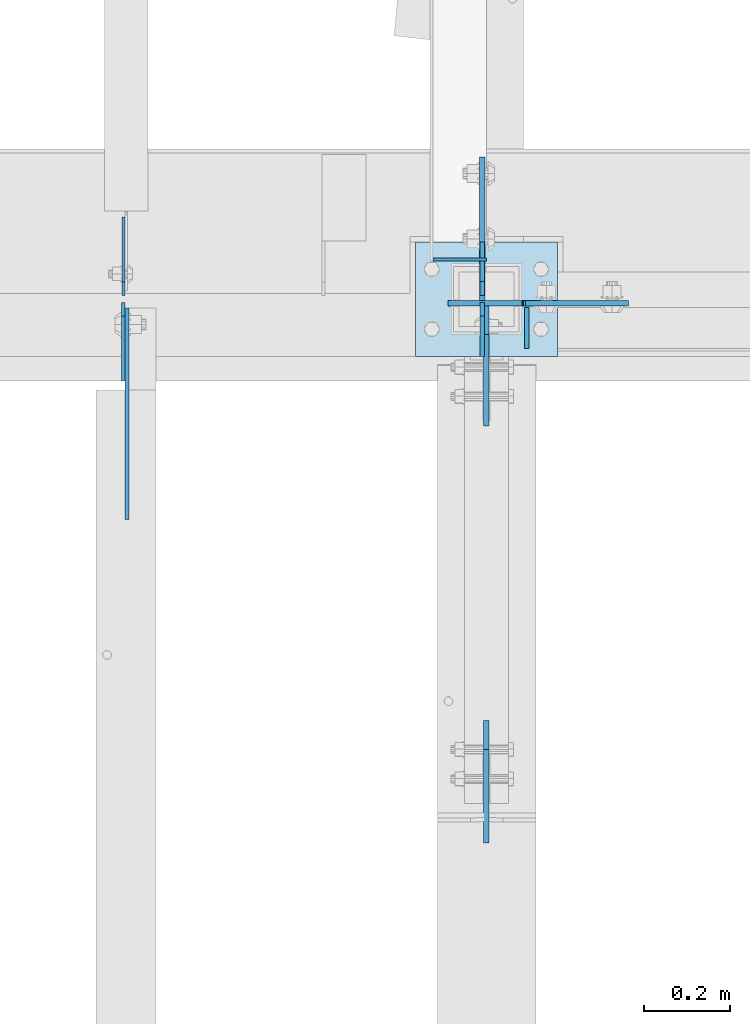
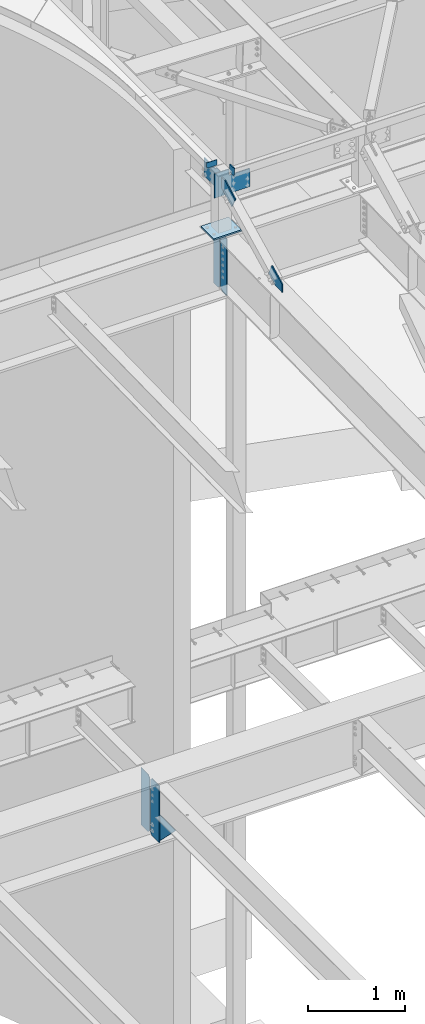
# One storey, part 1633 of 1763: 12 plates, 7 elements without a shape of their own.
"""IFC2X3 building model written with IfcOpenShell, lengths in millimetres."""

from ifc_helpers import new_model, si_unit, frame, origin_with_axes, place, context, subcontext, project, spatial, faceted_brep, material, type_object, element, aggregate, save


model = new_model("IFC2X3")

# Units and contexts
model_context = context("Model", 3, precision=1e-05, world=origin_with_axes())
body_context = subcontext(model_context, "Body", "Model", "MODEL_VIEW")
ifc_project = project(units=[si_unit("LENGTHUNIT", "METRE", prefix="MILLI"), si_unit("AREAUNIT", "SQUARE_METRE"), si_unit("VOLUMEUNIT", "CUBIC_METRE"), si_unit("MASSUNIT", "GRAM", prefix="KILO"), si_unit("TIMEUNIT", "SECOND"), si_unit("PLANEANGLEUNIT", "RADIAN"), si_unit("SOLIDANGLEUNIT", "STERADIAN"), si_unit("THERMODYNAMICTEMPERATUREUNIT", "DEGREE_CELSIUS"), si_unit("LUMINOUSINTENSITYUNIT", "LUMEN")], contexts=[model_context])

# Site, building, storey
site_placement = place(None, origin_with_axes())
site = spatial("IfcSite", under=ifc_project, at=site_placement, CompositionType="ELEMENT")
building_placement = place(site_placement, origin_with_axes())
building = spatial("IfcBuilding", under=site, at=building_placement, Name="Undefined", CompositionType="ELEMENT")
storey_placement = place(building_placement, origin_with_axes())
storey = spatial("IfcBuildingStorey", under=building, at=storey_placement, Name="Undefined", CompositionType="ELEMENT", Elevation=0.0)

# Assembly, plate
assembly_1_placement = place(storey_placement, origin_with_axes())
assembly_1 = element("IfcElementAssembly", 1, at=assembly_1_placement, inside=storey, Name="COLUMN", AssemblyPlace="NOTDEFINED", PredefinedType="RIGID_FRAME")
ifc_material_1 = material(Name="STEEL/A572-50")
plate_type_1 = type_object("IfcPlateType", PredefinedType="NOTDEFINED")
plate_1_placement = place(assembly_1_placement, frame((-41255.9882217781, 52111.275, 12484.1), z_axis=(0.0, 0.0, -1.0), x_axis=(-1.0, 0.0, 0.0)))
plate_1 = element("IfcPlate", 2, at=plate_1_placement, type_object=plate_type_1, material=ifc_material_1, Name="PLATE", context=body_context, shape_type="Brep", body=[
    faceted_brep([(-247.649993896484, -6.34999999999854, 76.2000000000007), (-247.649993896484, 6.34999999999854, 76.2000000000007), (-12.6999998092724, 6.34999999999854, 76.2000000000007), (-12.6999998092724, -6.34999999999854, 76.2000000000007), (-7.83992029122601, 6.34999999999854, 75.2332700774132), (-7.83992029122601, -6.34999999999854, 75.2332700774132), (-3.71974382307235, 6.34999999999854, 72.4802561769357), (-3.71974382307235, -6.34999999999854, 72.4802561769357), (-0.966729922598461, 6.34999999999854, 68.360079708782), (-0.966729922598461, -6.34999999999854, 68.360079708782), (-7.27595761418343e-12, -6.34999999999854, 63.5000001907356), (-7.27595761418343e-12, 6.34999999999854, 63.5000001907356), (0.0, 6.34999999999491, -2.91038304567337e-11), (0.0, -6.34999999999491, 1.45519152283669e-11), (-247.649993896484, -6.34999999999854, 304.799987792969), (171.449996948242, -6.34999999999854, 304.799987792969), (171.449996948242, 6.34999999999854, 304.799987792969), (-247.649993896484, 6.34999999999854, 304.799987792969), (171.449996948242, -6.34999999999854, 0.0), (171.449996948242, 6.34999999999854, 0.0)], [[[0, 1, 2, 3]], [[3, 2, 4, 5]], [[5, 4, 6, 7]], [[7, 6, 8, 9]], [[10, 11, 12, 13]], [[9, 8, 11, 10]], [[14, 15, 16, 17]], [[15, 18, 19, 16]], [[19, 18, 13, 12]], [[6, 4, 2, 1, 17, 16, 19, 12, 11, 8]], [[14, 17, 1, 0]], [[18, 15, 14, 0, 3, 5, 7, 9, 10, 13]]]),
])

assembly_2_placement = place(storey_placement, origin_with_axes())
assembly_2 = element("IfcElementAssembly", 3, at=assembly_2_placement, inside=storey, Name="BEAM", AssemblyPlace="NOTDEFINED", PredefinedType="RIGID_FRAME")
ifc_material_2 = material(Name="STEEL/A36")
plate_type_2 = type_object("IfcPlateType", PredefinedType="NOTDEFINED")
plate_2_placement = place(assembly_2_placement, frame((-41338.5382217802, 50858.8044431328, 11721.3897393295), z_axis=(0.0, -0.0206852279954837, 0.999786037781472), x_axis=(0.0, 0.999786037781472, 0.0206852279954825)))
plate_2 = element("IfcPlate", 4, at=plate_2_placement, type_object=plate_type_2, material=ifc_material_2, Name="PLATE", context=body_context, shape_type="Brep", body=[
    faceted_brep([(0.0, -6.34999999999491, 1.45519152283669e-11), (1.45519152283669e-11, -6.34999999999854, 101.599998474047), (1.45519152283669e-11, 6.34999999999854, 101.599998474047), (0.0, 6.34999999999491, -2.91038304567337e-11), (218.951583862981, -6.34999999999854, 205.463943481234), (218.951583862981, 6.34999999999854, 205.463943481234), (284.27273559654, -6.34999999999854, 67.7725906370797), (284.27273559654, 6.34999999999854, 67.7725906370797), (141.413955688891, -6.34999999999854, -4.72937244921923e-11), (141.413955688891, 6.34999999999854, -4.72937244921923e-11)], [[[0, 1, 2, 3]], [[1, 4, 5, 2]], [[4, 6, 7, 5]], [[6, 8, 9, 7]], [[8, 0, 3, 9]], [[5, 7, 9, 3, 2]], [[8, 6, 4, 1, 0]]]),
])
aggregate(assembly_2, [plate_2])

# Plate
plate_type_3 = type_object("IfcPlateType", PredefinedType="NOTDEFINED")
plate_3_placement = place(assembly_1_placement, frame((-41338.5382217802, 52104.9250000007, 12416.9092242053), z_axis=(0.0, -1.0, 0.0), x_axis=(0.0, 0.0, -1.0)))
plate_3 = element("IfcPlate", 5, at=plate_3_placement, type_object=plate_type_3, material=ifc_material_2, Name="PLATE", context=body_context, shape_type="Brep", body=[
    faceted_brep([(0.0, -6.34999999999491, 1.45519152283669e-11), (0.0, -6.34999999999854, 66.6750030517578), (0.0, 6.34999999999854, 66.6750030517578), (0.0, 6.34999999999491, -2.91038304567337e-11), (109.25341796875, -6.34999999999854, 278.831817626953), (109.25341796875, 6.34999999999854, 278.831817626953), (245.564117431641, -6.34999999999854, 210.676483154297), (245.564117431641, 6.34999999999854, 210.676483154297), (140.225875854492, -6.34999999999854, 0.0), (140.225875854492, 6.34999999999854, 0.0)], [[[0, 1, 2, 3]], [[1, 4, 5, 2]], [[4, 6, 7, 5]], [[6, 8, 9, 7]], [[8, 0, 3, 9]], [[5, 7, 9, 3, 2]], [[8, 6, 4, 1, 0]]]),
])

# Assembly, plate
assembly_3_placement = place(storey_placement, origin_with_axes())
assembly_3 = element("IfcElementAssembly", 6, at=assembly_3_placement, inside=storey, Name="BEAM", AssemblyPlace="NOTDEFINED", PredefinedType="RIGID_FRAME")
plate_type_4 = type_object("IfcPlateType", PredefinedType="NOTDEFINED")
plate_4_placement = place(assembly_3_placement, frame((-41244.8757217781, 52101.75, 12452.35), z_axis=(0.0, 0.0, 1.0), x_axis=(0.0, -1.0, 0.0)))
plate_4 = element("IfcPlate", 7, at=plate_4_placement, type_object=plate_type_4, material=ifc_material_2, Name="PLATE", context=body_context, shape_type="Brep", body=[
    faceted_brep([(0.0, -4.76249999999982, 0.0), (0.0, -4.76249999999709, 95.25), (0.0, 4.76249999999709, 95.25), (0.0, 4.76249999999982, 0.0), (95.25, -4.76249999999709, 95.25), (95.25, 4.76249999999709, 95.25), (95.25, -4.76249999999709, 19.0499992370605), (95.25, 4.76249999999709, 19.0499992370605), (76.1999969482931, -4.76249999991705, 0.0), (76.1999969482931, 4.76250000006257, 1.81898940354586e-12)], [[[0, 1, 2, 3]], [[1, 4, 5, 2]], [[4, 6, 7, 5]], [[6, 8, 9, 7]], [[8, 0, 3, 9]], [[5, 7, 9, 3, 2]], [[8, 6, 4, 1, 0]]]),
])
aggregate(assembly_3, [plate_4])

assembly_4_placement = place(storey_placement, origin_with_axes())
assembly_4 = element("IfcElementAssembly", 8, at=assembly_4_placement, inside=storey, Name="BEAM", AssemblyPlace="NOTDEFINED", PredefinedType="RIGID_FRAME")
plate_type_5 = type_object("IfcPlateType", PredefinedType="NOTDEFINED")
plate_5_placement = place(assembly_4_placement, frame((-41463.3380411022, 52212.8535679558, 12501.364063), z_axis=(0.0, 0.0, 1.0), x_axis=(1.0, 0.0, 0.0)))
plate_5 = element("IfcPlate", 9, at=plate_5_placement, type_object=plate_type_5, material=ifc_material_2, Name="PLATE", context=body_context, shape_type="Brep", body=[
    faceted_brep([(0.0, -3.17500000000291, 19.0499992370605), (0.0, -3.17500000000291, 69.8499984741211), (7.27595761418343e-12, 3.17500000000291, 69.8499984741211), (7.27595761418343e-12, 3.17500000000291, 19.0499992370605), (124.799827575684, -3.17500000022847, 69.8499984741211), (124.799827575691, 3.17499999977736, 69.8499984741211), (124.799781799316, -3.17499999999927, 0.0), (124.799781799316, 3.17499999999927, 0.0), (19.0499992370605, -3.17500000003929, 0.0), (19.0499992370678, 3.17499999995925, 0.0)], [[[0, 1, 2, 3]], [[1, 4, 5, 2]], [[4, 6, 7, 5]], [[6, 8, 9, 7]], [[8, 0, 3, 9]], [[5, 7, 9, 3, 2]], [[8, 6, 4, 1, 0]]]),
])
aggregate(assembly_4, [plate_5])

# Assembly, plates
assembly_5_placement = place(storey_placement, origin_with_axes())
assembly_5 = element("IfcElementAssembly", 10, at=assembly_5_placement, inside=storey, Name="BEAM", AssemblyPlace="NOTDEFINED", PredefinedType="RIGID_FRAME")
plate_type_6 = type_object("IfcPlateType", PredefinedType="NOTDEFINED")
plate_6_placement = place(assembly_5_placement, frame((-42182.487273746, 52128.7375, 4448.175), z_axis=(0.0, 0.0, 1.0), x_axis=(0.0, 1.0, 0.0)))
plate_6 = element("IfcPlate", 11, at=plate_6_placement, type_object=plate_type_6, material=ifc_material_2, Name="PLATE", context=body_context, shape_type="Brep", body=[
    faceted_brep([(0.0, -3.17500000000291, 31.75), (0.0, -3.17500000000291, 687.387512207031), (0.0, 3.17500000000291, 687.387512207031), (0.0, 3.17500000000291, 31.75), (31.75, -3.17500000000291, 719.137512207031), (31.75, 3.17500000000291, 719.137512207031), (182.5625, -3.17500000000291, 719.137512207031), (182.5625, 3.17500000000291, 719.137512207031), (182.5625, -3.17500000000291, 0.0), (182.5625, 3.17500000000291, 0.0), (31.7499999999036, -3.17499999997381, 9.42916855706244e-11), (31.7499999998854, 3.17500000000291, 9.42916855706244e-11)], [[[0, 1, 2, 3]], [[1, 4, 5, 2]], [[4, 6, 7, 5]], [[6, 8, 9, 7]], [[8, 10, 11, 9]], [[10, 0, 3, 11]], [[5, 7, 9, 11, 3, 2]], [[10, 8, 6, 4, 1, 0]]]),
])
plate_type_7 = type_object("IfcPlateType", PredefinedType="NOTDEFINED")
plate_7_placement = place(assembly_5_placement, frame((-42183.2820237632, 52112.8625, 4448.175), z_axis=(0.0, 0.0, 1.0), x_axis=(0.0, -1.0, 0.0)))
plate_7 = element("IfcPlate", 12, at=plate_7_placement, type_object=plate_type_7, material=ifc_material_2, Name="PLATE", context=body_context, shape_type="Brep", body=[
    faceted_brep([(0.0, -3.96899999999732, 31.75), (0.0, -3.96899999999732, 687.387512207031), (0.0, 3.96899999999732, 687.387512207031), (0.0, 3.96899999999732, 31.75), (31.75, -3.96899999999732, 719.137512207031), (31.75, 3.96899999999732, 719.137512207031), (182.5625, -3.96899999999732, 719.137512207031), (182.5625, 3.96899999999732, 719.137512207031), (182.5625, -3.96899999999732, 0.0), (182.5625, 3.96899999999732, 0.0), (31.75, -3.96899999999732, 0.0), (31.75, 3.96899999999732, 0.0)], [[[0, 1, 2, 3]], [[1, 4, 5, 2]], [[4, 6, 7, 5]], [[6, 8, 9, 7]], [[8, 10, 11, 9]], [[10, 0, 3, 11]], [[5, 7, 9, 11, 3, 2]], [[10, 8, 6, 4, 1, 0]]]),
])
aggregate(assembly_5, [plate_6, plate_7])

# Assembly, plate
assembly_6_placement = place(storey_placement, origin_with_axes())
assembly_6 = element("IfcElementAssembly", 13, at=assembly_6_placement, inside=storey, Name="BEAM", AssemblyPlace="NOTDEFINED", PredefinedType="RIGID_FRAME")
plate_type_8 = type_object("IfcPlateType", PredefinedType="NOTDEFINED")
plate_8_placement = place(assembly_6_placement, frame((-42174.549773746, 51930.3004272461, 4794.2499684514), z_axis=(0.0, 0.0, -1.0), x_axis=(0.0, -1.0, 0.0)))
plate_8 = element("IfcPlate", 14, at=plate_8_placement, type_object=plate_type_8, material=ifc_material_2, Name="PLATE", context=body_context, shape_type="Brep", body=[
    faceted_brep([(0.0, -4.76249999999982, 0.0), (-169.862075805664, -4.76249999999709, 6.30279828328639e-10), (-169.862075805664, 4.76249999999709, 6.30279828328639e-10), (0.0, 4.76249999999982, 0.0), (-169.862091064453, -4.76249999999709, 323.002471923828), (-169.862091064453, 4.76249999999709, 323.002471923828), (6.38101482763886e-09, -4.76249999999709, 323.002471923828), (6.38101482763886e-09, 4.76249999999709, 323.002471923828), (322.262145996094, -4.76249999999709, -1.15778675535694e-09), (322.262145996094, 4.76249999999709, -1.15778675535694e-09)], [[[0, 1, 2, 3]], [[1, 4, 5, 2]], [[4, 6, 7, 5]], [[6, 8, 9, 7]], [[8, 0, 3, 9]], [[5, 7, 9, 3, 2]], [[8, 6, 4, 1, 0]]]),
])
aggregate(assembly_6, [plate_8])

# Plate
plate_type_9 = type_object("IfcPlateType", PredefinedType="NOTDEFINED")
plate_9_placement = place(assembly_1_placement, frame((-41348.063221772, 52209.700000001, 12482.314063), z_axis=(0.0, 0.0, -1.0), x_axis=(0.0, -1.0, 0.0)))
plate_9 = element("IfcPlate", 15, at=plate_9_placement, type_object=plate_type_9, material=ifc_material_1, Name="PLATE", context=body_context, shape_type="Brep", body=[
    faceted_brep([(-241.300003051758, -6.34999999999854, 25.3999999999996), (-241.300003051758, 6.34999999999854, 25.3999999999996), (-6.34999980926659, 6.34999999999854, 25.3999999999996), (-6.34999980926659, -6.34999999999854, 25.3999999999996), (-1.48992029122019, 6.34999999999854, 24.4332700774121), (-1.48992029122019, -6.34999999999854, 24.4332700774121), (2.63025617693347, 6.34999999999854, 21.6802561769346), (2.63025617693347, -6.34999999999854, 21.6802561769346), (5.38327007740736, 6.34999999999854, 17.5600797087809), (5.38327007740736, -6.34999999999854, 17.5600797087809), (6.34999999999854, -6.34999999999854, 12.7000001907345), (6.34999999999854, 6.34999999999854, 12.7000001907345), (6.35000000000582, 6.35000000000036, 0.0), (6.34999990463257, -6.35000000000291, 0.0), (-241.300003051758, -6.34999999999854, 254.0), (92.0749969482422, -6.34999999999854, 254.0), (92.0749969482422, 6.34999999999854, 254.0), (-241.300003051758, 6.34999999999854, 254.0), (92.0749969482422, -6.34999999999854, 0.0), (92.0749969482422, 6.34999999999854, 0.0)], [[[0, 1, 2, 3]], [[3, 2, 4, 5]], [[5, 4, 6, 7]], [[7, 6, 8, 9]], [[10, 11, 12, 13]], [[9, 8, 11, 10]], [[14, 15, 16, 17]], [[15, 18, 19, 16]], [[19, 18, 13, 12]], [[6, 4, 2, 1, 17, 16, 19, 12, 11, 8]], [[14, 17, 1, 0]], [[18, 15, 14, 0, 3, 5, 7, 9, 10, 13]]]),
])

# Assembly, plates
assembly_7_placement = place(storey_placement, origin_with_axes())
assembly_7 = element("IfcElementAssembly", 16, at=assembly_7_placement, inside=storey, Name="BEAM", AssemblyPlace="NOTDEFINED", PredefinedType="RIGID_FRAME")
plate_type_10 = type_object("IfcPlateType", PredefinedType="NOTDEFINED")
plate_10_placement = place(assembly_7_placement, frame((-41348.2322697605, 52128.7375002128, 10999.7874917654), z_axis=(0.0, 0.0, 1.0), x_axis=(0.0, 1.0, 0.0)))
plate_10 = element("IfcPlate", 17, at=plate_10_placement, type_object=plate_type_10, material=ifc_material_2, Name="PLATE", context=body_context, shape_type="Brep", body=[
    faceted_brep([(0.0, -4.76249999999709, 33.3375015258789), (0.0, -4.76249999999709, 684.21248626709), (0.0, 4.76249999999709, 684.21248626709), (0.0, 4.76249999999709, 33.3375015258789), (33.3375015258789, -4.76249999999709, 717.549987792969), (33.3375015258789, 4.76249999999709, 717.549987792969), (125.412498474121, -4.76249999999709, 717.549987792969), (125.412498474121, 4.76249999999709, 717.549987792969), (125.412498474121, -4.76249999999709, 0.0), (125.412498474121, 4.76249999999709, 0.0), (33.3375015258789, -4.76249999999709, 0.0), (33.3375015258789, 4.76249999999709, 0.0)], [[[0, 1, 2, 3]], [[1, 4, 5, 2]], [[4, 6, 7, 5]], [[6, 8, 9, 7]], [[8, 10, 11, 9]], [[10, 0, 3, 11]], [[5, 7, 9, 11, 3, 2]], [[10, 8, 6, 4, 1, 0]]]),
])
plate_11_placement = place(assembly_7_placement, frame((-41348.23226976, 52112.8625002128, 10999.7874917654), z_axis=(0.0, 0.0, 1.0), x_axis=(0.0, -1.0, 0.0)))
plate_11 = element("IfcPlate", 18, at=plate_11_placement, type_object=plate_type_10, material=ifc_material_2, Name="PLATE", context=body_context, shape_type="Brep", body=[
    faceted_brep([(0.0, -4.76250000000073, 31.75), (0.0, -4.76250000000073, 685.799987792969), (0.0, 4.76250000000073, 685.799987792969), (0.0, 4.76250000000073, 31.75), (31.75, -4.76250000000073, 717.549987792969), (31.75, 4.76250000000073, 717.549987792969), (125.412498474121, -4.76249999999709, 717.549987792969), (125.412498474121, 4.76249999999709, 717.549987792969), (125.412498474121, -4.76249999999709, 0.0), (125.412498474121, 4.76249999999709, 0.0), (31.75, -4.76250000000073, 0.0), (31.75, 4.76250000000073, 0.0)], [[[0, 1, 2, 3]], [[1, 4, 5, 2]], [[4, 6, 7, 5]], [[6, 8, 9, 7]], [[8, 10, 11, 9]], [[10, 0, 3, 11]], [[5, 7, 9, 11, 3, 2]], [[10, 8, 6, 4, 1, 0]]]),
])
aggregate(assembly_7, [plate_10, plate_11])

# Plate
plate_type_11 = type_object("IfcPlateType", PredefinedType="NOTDEFINED")
plate_12_placement = place(assembly_1_placement, frame((-41503.6382217781, 52254.1500002138, 11757.0249917654), z_axis=(1.0, 0.0, 0.0), x_axis=(0.0, -1.0, 0.0)))
plate_12 = element("IfcPlate", 19, at=plate_12_placement, type_object=plate_type_11, material=ifc_material_2, Name="PLATE", context=body_context, shape_type="Brep", body=[
    faceted_brep([(0.0, -9.52500000000146, 0.0), (0.0, -9.52500000025611, 330.200012207846), (0.0, 9.52499999975589, 330.200012207861), (0.0, 9.52500000000146, 0.0), (266.700012207031, -9.52499999999964, 330.200012207031), (266.700012207031, 9.52499999999964, 330.200012207031), (266.700012207031, -9.52499999999964, 0.0), (266.700012207031, 9.52499999999964, 0.0)], [[[0, 1, 2, 3]], [[1, 4, 5, 2]], [[4, 6, 7, 5]], [[6, 0, 3, 7]], [[5, 7, 3, 2]], [[6, 4, 1, 0]]]),
])

aggregate(assembly_1, [plate_3, plate_1, plate_9, plate_12])

save(model, "model.ifc")
